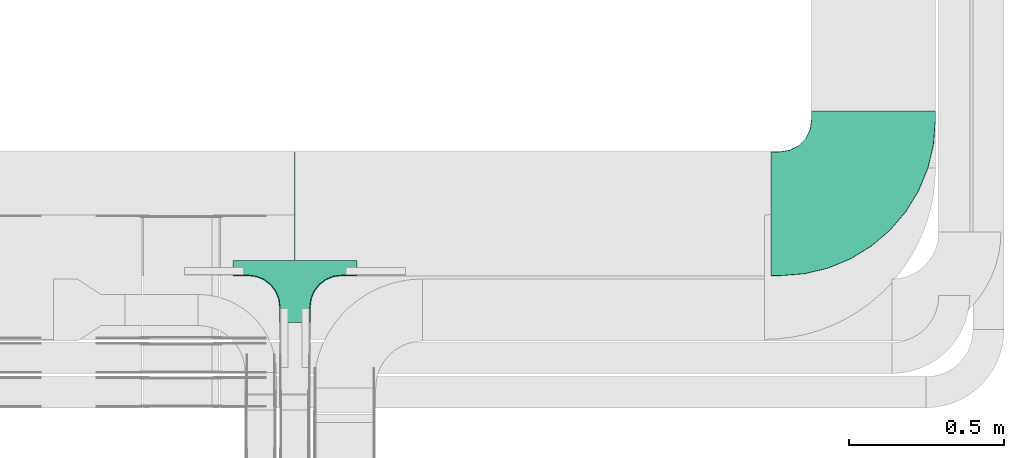
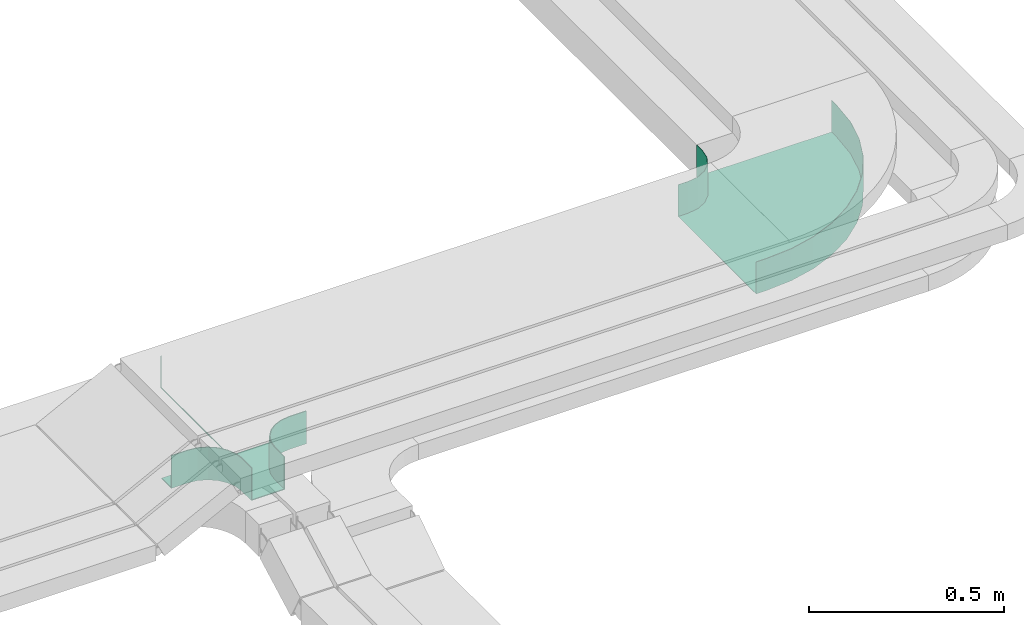
# One storey, part 28 of 28: 2 flow fittings.
"""IFC2X3 building model written with IfcOpenShell, lengths in millimetres."""

from ifc_helpers import new_model, entity, si_unit, converted_unit, derived_unit, direction, frame, origin, place, context, subcontext, project, spatial, faceted_brep, source, transform, mapped, material, type_object, type_shapes, element, save


model = new_model("IFC2X3")

# Units and contexts
model_context = context("Model", 3, precision=0.01, world=origin(), true_north=direction((6.12303176911189e-17, 1.0)))
body_context = subcontext(model_context, "Body", "Model", "MODEL_VIEW")
ifc_project = project(units=[si_unit("LENGTHUNIT", "METRE", prefix="MILLI"), si_unit("AREAUNIT", "SQUARE_METRE"), si_unit("VOLUMEUNIT", "CUBIC_METRE"), converted_unit("PLANEANGLEUNIT", "DEGREE", entity("IfcRatioMeasure", 0.0174532925199433), si_unit("PLANEANGLEUNIT", "RADIAN"), dimensions=[0, 0, 0, 0, 0, 0, 0]), si_unit("MASSUNIT", "GRAM", prefix="KILO"), derived_unit("MASSDENSITYUNIT", [(si_unit("MASSUNIT", "GRAM", prefix="KILO"), 1), (si_unit("LENGTHUNIT", "METRE"), -3)]), derived_unit("MOMENTOFINERTIAUNIT", [(si_unit("LENGTHUNIT", "METRE"), 4)]), si_unit("TIMEUNIT", "SECOND"), si_unit("FREQUENCYUNIT", "HERTZ"), si_unit("THERMODYNAMICTEMPERATUREUNIT", "DEGREE_CELSIUS"), derived_unit("THERMALTRANSMITTANCEUNIT", [(si_unit("MASSUNIT", "GRAM", prefix="KILO"), 1), (si_unit("THERMODYNAMICTEMPERATUREUNIT", "KELVIN"), -1), (si_unit("TIMEUNIT", "SECOND"), -3)]), derived_unit("VOLUMETRICFLOWRATEUNIT", [(si_unit("LENGTHUNIT", "METRE"), 3), (si_unit("TIMEUNIT", "SECOND"), -1)]), derived_unit("MASSFLOWRATEUNIT", [(si_unit("MASSUNIT", "GRAM", prefix="KILO"), 1), (si_unit("TIMEUNIT", "SECOND"), -1)]), derived_unit("ROTATIONALFREQUENCYUNIT", [(si_unit("TIMEUNIT", "SECOND"), -1)]), si_unit("ELECTRICCURRENTUNIT", "AMPERE"), si_unit("ELECTRICVOLTAGEUNIT", "VOLT"), si_unit("POWERUNIT", "WATT"), si_unit("FORCEUNIT", "NEWTON", prefix="KILO"), si_unit("ILLUMINANCEUNIT", "LUX"), si_unit("LUMINOUSFLUXUNIT", "LUMEN"), si_unit("LUMINOUSINTENSITYUNIT", "CANDELA"), derived_unit("USERDEFINED", [(si_unit("MASSUNIT", "GRAM", prefix="KILO"), -1), (si_unit("LENGTHUNIT", "METRE"), -2), (si_unit("TIMEUNIT", "SECOND"), 3), (si_unit("LUMINOUSFLUXUNIT", "LUMEN"), 1)]), derived_unit("LINEARVELOCITYUNIT", [(si_unit("LENGTHUNIT", "METRE"), 1), (si_unit("TIMEUNIT", "SECOND"), -1)]), si_unit("PRESSUREUNIT", "PASCAL"), derived_unit("USERDEFINED", [(si_unit("LENGTHUNIT", "METRE"), -2), (si_unit("MASSUNIT", "GRAM", prefix="KILO"), 1), (si_unit("TIMEUNIT", "SECOND"), -2)]), derived_unit("LINEARFORCEUNIT", [(si_unit("MASSUNIT", "GRAM", prefix="KILO"), 1), (si_unit("LENGTHUNIT", "METRE"), 1), (si_unit("TIMEUNIT", "SECOND"), -2), (si_unit("LENGTHUNIT", "METRE"), -1)]), derived_unit("PLANARFORCEUNIT", [(si_unit("MASSUNIT", "GRAM", prefix="KILO"), 1), (si_unit("LENGTHUNIT", "METRE"), 1), (si_unit("TIMEUNIT", "SECOND"), -2), (si_unit("LENGTHUNIT", "METRE"), -2)])], contexts=[model_context])

# Site, building, storey
site_placement = place(None, frame((0.0, -0.00077364408347762, 0.0)))
site = spatial("IfcSite", under=ifc_project, at=site_placement, CompositionType="ELEMENT")
building_placement = place(site_placement, origin())
building = spatial("IfcBuilding", under=site, at=building_placement, CompositionType="ELEMENT")
storey_placement = place(building_placement, origin())
storey = spatial("IfcBuildingStorey", under=building, at=storey_placement, CompositionType="ELEMENT", Elevation=0.0)

# Flow fittings
ifc_material_1 = material()
cable_carrier_fitting_type_1 = type_object("IfcCableCarrierFittingType", PredefinedType="NOTDEFINED", material=ifc_material_1)
shared_shape_1 = source(origin(), body_context, "Body", "Brep", [
    faceted_brep([(1.0, 197.500000000001, 50.0), (1.0, 197.500000000001, -47.500000000001), (1.0, -200.0, -47.500000000001), (1.0, -200.0, -50.0), (1.0, 200.0, -50.0), (1.0, 200.0, 50.0), (-1.0, 197.500000000001, 50.0), (-1.0, 200.0, 50.0), (-1.0, 200.0, -50.0), (-1.0, -200.0, -50.0), (-1.0, -200.0, -47.500000000001), (-1.0, 197.500000000001, -47.500000000001)], [[[0, 1, 2, 3, 4, 5]], [[6, 7, 8, 9, 10, 11]], [[1, 0, 6, 11]], [[2, 1, 11, 10]], [[3, 2, 10, 9]], [[4, 3, 9, 8]], [[5, 4, 8, 7]], [[0, 5, 7, 6]]]),
    faceted_brep([(47.4999999999995, -300.0, 50.0), (47.4999999999995, -350.0, 50.0), (50.0, -350.0, 50.0), (50.0, -300.0, 50.0), (53.4074173710929, -274.118095489749, 50.0), (63.3974596215558, -250.0, 50.0), (79.2893218813448, -229.289321881346, 50.0), (100.0, -213.397459621557, 50.0), (124.118095489747, -203.407417371094, 50.0), (150.0, -200.0, 50.0), (200.0, -200.0, 50.0), (200.0, -197.500000000001, 50.0), (150.0, -197.500000000001, 50.0), (123.471047876992, -200.992602805371, 50.0), (98.75, -211.232396112096, 50.0), (77.5215549283788, -227.521554928379, 50.0), (61.2323961120949, -248.750000000001, 50.0), (50.9926028053703, -273.471047876992, 50.0), (-124.118095489753, -203.407417371094, 50.0), (-100.0, -213.397459621557, 50.0), (-79.289321881351, -229.289321881346, 50.0), (-63.3974596215619, -250.0, 50.0), (-53.407417371099, -274.118095489749, 50.0), (-50.0, -300.0, 50.0), (-50.0, -350.0, 50.0), (-47.5000000000058, -350.0, 50.0), (-47.5000000000059, -300.0, 50.0), (-50.9926028053763, -273.471047876993, 50.0), (-61.2323961121008, -248.750000000001, 50.0), (-77.5215549283845, -227.52155492838, 50.0), (-98.7500000000056, -211.232396112096, 50.0), (-123.471047876997, -200.992602805371, 50.0), (-150.0, -197.500000000001, 50.0), (-200.0, -197.500000000001, 50.0), (-200.0, -200.0, 50.0), (-150.0, -200.0, 50.0), (-124.118095489754, -203.407417371094, -50.0), (-139.212641733723, -201.420182658132, -50.0), (-150.0, -200.0, -50.0), (-150.0, -200.0, -52.5000000000001), (-137.05904774488, -201.703708685552, -52.5000000000001), (-124.118095489753, -203.407417371099, -52.5000000000001), (-100.0, -213.397459621557, -50.0), (-112.059047744882, -208.402438496329, -50.0), (-112.05904774488, -208.40243849633, -52.5000000000001), (-100.0, -213.397459621562, -52.5000000000001), (-89.6446609406813, -221.343390751454, -50.0), (-79.2893218813514, -229.289321881346, -50.0), (-89.6446609406784, -221.343390751456, -52.5000000000001), (-79.2893218813506, -229.289321881351, -52.5000000000001), (-53.4074173710992, -274.118095489748, -50.0), (-58.4024384963323, -262.059047744874, -50.0), (-63.3974596215623, -250.0, -50.0), (-63.3974596215616, -250.0, -52.5000000000001), (-58.4024384963304, -262.059047744879, -52.5000000000001), (-53.4074173710987, -274.118095489754, -52.5000000000001), (-50.0, -300.0, -50.0), (-51.7037086855529, -287.059047744874, -50.0), (-51.420182658065, -289.21264173423, -52.5000000000001), (-50.0, -300.0, -52.5000000000001), (-71.3433907514592, -239.644660940674, -50.0), (-71.3433907514565, -239.644660940678, -52.5000000000001), (-50.0, -350.0, -52.5000000000001), (50.0, -350.0, -52.5000000000001), (47.4999999999995, -350.0, -50.0), (-47.5000000000058, -350.0, -50.0), (-47.5000000000058, -300.0, -50.0), (-50.9926028053762, -273.471047876993, -50.0), (-61.2323961121005, -248.750000000002, -50.0), (-77.5215549283841, -227.52155492838, -50.0), (-98.750000000005, -211.232396112096, -50.0), (-123.471047876996, -200.992602805372, -50.0), (-150.0, -197.500000000001, -50.0), (50.0, -300.0, -52.5000000000001), (50.0, -300.0, -50.0), (53.4074173710928, -274.11809548975, -50.0), (58.4024384963256, -262.059047744877, -50.0), (63.3974596215555, -250.0, -50.0), (53.4074173710929, -274.118095489754, -52.5000000000001), (58.402438496324, -262.059047744881, -52.5000000000001), (63.3974596215557, -250.0, -52.5000000000001), (71.343390751452, -239.644660940677, -50.0), (79.2893218813444, -229.289321881347, -50.0), (71.3433907514499, -239.644660940679, -52.5000000000001), (79.2893218813448, -229.289321881352, -52.5000000000001), (51.4201826582159, -289.212641733042, -50.0), (51.7037086855462, -287.059047744881, -52.5), (100.0, -213.397459621557, -50.0), (112.059047744874, -208.40243849633, -50.0), (124.118095489747, -203.407417371094, -50.0), (100.0, -213.397459621562, -52.5000000000001), (112.059047744873, -208.402438496331, -52.5000000000001), (124.118095489748, -203.407417371099, -52.5000000000001), (137.059047744873, -201.703708685553, -50.0), (150.0, -200.0, -50.0), (139.212641734219, -201.420182658066, -52.5000000000001), (150.0, -200.0, -52.5000000000001), (89.6446609406736, -221.343390751456, -50.0), (89.6446609406717, -221.343390751457, -52.5000000000001), (123.471047876991, -200.992602805371, -50.0), (98.7499999999995, -211.232396112096, -50.0), (77.5215549283783, -227.52155492838, -50.0), (150.0, -197.500000000001, -50.0), (61.2323961120945, -248.750000000001, -50.0), (50.9926028053701, -273.471047876993, -50.0), (47.4999999999997, -300.0, -50.0), (-200.0, -197.500000000001, -50.0), (200.0, -197.500000000001, -50.0), (-200.0, -150.0, -50.0), (-200.0, -150.0, -52.5000000000001), (-200.0, -200.0, -52.5000000000001), (200.0, -200.0, -52.5000000000001), (200.0, -150.0, -52.5000000000001), (200.0, -150.0, -50.0)], [[[0, 1, 2, 3, 4, 5, 6, 7, 8, 9, 10, 11, 12, 13, 14, 15, 16, 17]], [[18, 19, 20, 21, 22, 23, 24, 25, 26, 27, 28, 29, 30, 31, 32, 33, 34, 35]], [[18, 35, 36]], [[35, 37, 36]], [[35, 38, 37]], [[37, 38, 39]], [[37, 39, 40]], [[36, 40, 41]], [[37, 40, 36]], [[19, 18, 42]], [[18, 43, 42]], [[18, 36, 43]], [[36, 41, 43]], [[44, 43, 41]], [[43, 44, 42]], [[44, 45, 42]], [[19, 42, 46]], [[19, 46, 47]], [[47, 20, 19]], [[46, 42, 45]], [[46, 45, 48]], [[48, 49, 47]], [[46, 48, 47]], [[22, 21, 50]], [[21, 51, 50]], [[21, 52, 51]], [[52, 53, 51]], [[54, 51, 53]], [[51, 54, 50]], [[54, 55, 50]], [[23, 22, 56]], [[22, 57, 56]], [[22, 50, 57]], [[50, 55, 57]], [[58, 57, 55]], [[58, 59, 56]], [[57, 58, 56]], [[20, 47, 60]], [[20, 60, 52]], [[52, 21, 20]], [[60, 47, 49]], [[60, 49, 61]], [[60, 61, 52]], [[61, 53, 52]], [[24, 23, 56, 59, 62]], [[25, 24, 62, 63, 2, 1, 64, 65]], [[26, 25, 65, 66]], [[27, 67, 68, 28]], [[28, 68, 69, 29]], [[66, 67, 27, 26]], [[30, 70, 71, 31]], [[31, 71, 72, 32]], [[29, 69, 70, 30]], [[3, 2, 63, 73, 74]], [[5, 4, 75]], [[5, 75, 76]], [[5, 76, 77]], [[75, 78, 76]], [[79, 76, 78]], [[76, 79, 77]], [[79, 80, 77]], [[6, 5, 77]], [[6, 77, 81]], [[6, 81, 82]], [[81, 77, 80]], [[81, 80, 83]], [[83, 84, 82]], [[81, 83, 82]], [[74, 4, 3]], [[4, 74, 85]], [[85, 74, 73]], [[85, 73, 86]], [[85, 86, 75]], [[75, 86, 78]], [[4, 85, 75]], [[8, 7, 87]], [[8, 87, 88]], [[8, 88, 89]], [[87, 90, 88]], [[91, 88, 90]], [[88, 91, 89]], [[91, 92, 89]], [[9, 8, 89]], [[9, 89, 93]], [[9, 93, 94]], [[89, 92, 93]], [[95, 93, 92]], [[95, 96, 94]], [[93, 95, 94]], [[7, 82, 97]], [[6, 82, 7]], [[7, 97, 87]], [[97, 82, 84]], [[97, 84, 98]], [[97, 98, 87]], [[98, 90, 87]], [[13, 99, 100, 14]], [[14, 100, 101, 15]], [[102, 99, 13, 12]], [[16, 103, 104, 17]], [[17, 104, 105, 0]], [[15, 101, 103, 16]], [[1, 0, 105, 64]], [[33, 32, 72, 106]], [[12, 11, 107, 102]], [[34, 33, 106, 108, 109, 110]], [[35, 34, 110, 39, 38]], [[10, 9, 94, 96, 111]], [[10, 111, 112, 113, 107, 11]], [[107, 113, 108, 106, 72, 71, 70, 69, 68, 67, 66, 65, 64, 105, 104, 103, 101, 100, 99, 102]], [[110, 109, 112, 111, 96, 95, 92, 91, 90, 98, 84, 83, 80, 79, 78, 86, 73, 63, 62, 59, 58, 55, 54, 53, 61, 49, 48, 45, 44, 41, 40, 39]], [[108, 113, 112, 109]]]),
])
type_shapes(cable_carrier_fitting_type_1, [shared_shape_1])
flow_fitting_1_placement = place(storey_placement, frame((66384.9973266601, 8924.32755701973, 2650.0)))
element("IfcFlowFitting", 1, at=flow_fitting_1_placement, inside=storey, type_object=cable_carrier_fitting_type_1, material=ifc_material_1, context=body_context, shape_type="MappedRepresentation", body=[
    mapped(shared_shape_1, transform((0.0, 0.0, 0.0), scale=1.0)),
])
ifc_material_2 = material()
cable_carrier_fitting_type_2 = type_object("IfcCableCarrierFittingType", Name="470_DKC_S5_CPO 45 horizontal angle:-", PredefinedType="NOTDEFINED", material=ifc_material_2)
shared_shape_2 = source(origin(), body_context, "Body", "Brep", [
    faceted_brep([(-330.0, -200.0, -50.0), (-330.0, -200.0, 50.0), (-330.0, -199.200000000008, 50.0), (-330.0, -199.200000000008, -49.2000000000019), (-330.0, 199.199999999992, -49.2000000000019), (-330.0, 199.199999999992, 50.0), (-330.0, 200.0, 50.0), (-330.0, 200.0, -50.0), (-300.0, -200.0, -50.0), (-300.0, -200.0, 50.0), (-221.782767479876, -193.844170297577, 50.0), (-145.491502812517, -175.528258147585, 50.0), (-73.0047501302177, -145.503262094192, 50.0), (-6.10737385375454, -104.508497187482, 50.0), (53.5533905932826, -53.5533905932825, 50.0), (104.508497187483, 6.10737385375464, 50.0), (145.503262094193, 73.0047501302177, 50.0), (175.528258147586, 145.491502812517, 50.0), (193.844170297578, 221.782767479875, 50.0), (200.0, 300.0, 50.0), (200.0, 330.0, 50.0), (199.200000000009, 330.0, 50.0), (199.200000000009, 300.0, 50.0), (193.054019625102, 221.907915051908, 50.0), (174.76741293455, 145.738716408017, 50.0), (144.790456874842, 73.3679425300094, 50.0), (103.861283591982, 6.5776020555887, 50.0), (52.9877051683332, -52.9877051683332, 50.0), (-6.5776020555887, -103.861283591982, 50.0), (-73.3679425300094, -144.790456874842, 50.0), (-145.738716408017, -174.767412934549, 50.0), (-221.907915051908, -193.054019625101, 50.0), (-300.0, -199.200000000008, 50.0), (-300.0, 199.199999999992, 50.0), (-268.851086966996, 204.13350315744, 50.0), (-240.75124656891, 218.451086966997, 50.0), (-218.451086966996, 240.75124656891, 50.0), (-204.13350315744, 268.851086966997, 50.0), (-199.199999999991, 300.0, 50.0), (-199.199999999991, 330.0, 50.0), (-200.0, 330.0, 50.0), (-200.0, 300.0, 50.0), (-204.894348370476, 269.098300562497, 50.0), (-219.098300562496, 241.221474770744, 50.0), (-241.221474770744, 219.098300562497, 50.0), (-269.098300562496, 204.894348370476, 50.0), (-300.0, 200.0, 50.0), (-300.0, -199.200000000008, -49.2000000000019), (-221.907915051908, -193.054019625101, -49.2000000000018), (-145.738716408017, -174.767412934549, -49.2000000000018), (-73.3679425300094, -144.790456874842, -49.2000000000018), (-6.5776020555887, -103.861283591982, -49.2000000000018), (52.9877051683332, -52.9877051683332, -49.2000000000018), (103.861283591982, 6.5776020555887, -49.2000000000018), (144.790456874842, 73.3679425300094, -49.2000000000017), (174.76741293455, 145.738716408017, -49.2000000000017), (193.054019625102, 221.907915051908, -49.2000000000017), (199.200000000009, 300.0, -49.2000000000017), (199.200000000009, 330.0, -49.2000000000017), (-199.199999999991, 330.0, -49.2000000000018), (-199.199999999991, 300.0, -49.2000000000018), (-204.13350315744, 268.851086966997, -49.2000000000018), (-218.451086966996, 240.75124656891, -49.2000000000018), (-240.75124656891, 218.451086966997, -49.2000000000019), (-268.851086966996, 204.13350315744, -49.2000000000019), (-300.0, 199.199999999992, -49.2000000000019), (-300.0, 200.0, -50.0), (-221.782767479876, -193.844170297577, -50.0), (-269.098300562496, 204.894348370476, -50.0), (-241.221474770744, 219.098300562497, -50.0), (-219.098300562496, 241.221474770744, -50.0), (-204.894348370476, 269.098300562497, -50.0), (-200.0, 300.0, -50.0), (-200.0, 330.0, -50.0), (200.0, 330.0, -50.0), (200.0, 300.0, -50.0), (193.844170297578, 221.782767479875, -50.0), (175.528258147586, 145.491502812517, -50.0), (145.503262094193, 73.0047501302177, -50.0), (104.508497187483, 6.10737385375464, -50.0), (53.5533905932826, -53.5533905932825, -50.0), (-6.10737385375454, -104.508497187482, -50.0), (-73.0047501302177, -145.503262094192, -50.0), (-145.491502812517, -175.528258147585, -50.0)], [[[0, 1, 2, 3, 4, 5, 6, 7]], [[1, 0, 8, 9]], [[1, 9, 10, 11, 12, 13, 14, 15, 16, 17, 18, 19, 20, 21, 22, 23, 24, 25, 26, 27, 28, 29, 30, 31, 32, 2]], [[6, 5, 33, 34, 35, 36, 37, 38, 39, 40, 41, 42, 43, 44, 45, 46]], [[3, 2, 32, 47]], [[4, 3, 47, 48, 49, 50, 51, 52, 53, 54, 55, 56, 57, 58, 59, 60, 61, 62, 63, 64, 65]], [[5, 4, 65, 33]], [[7, 6, 46, 66]], [[67, 8, 0, 7, 66, 68, 69, 70, 71, 72, 73, 74, 75, 76, 77, 78, 79, 80, 81, 82, 83]], [[10, 9, 8, 67]], [[67, 83, 11, 10]], [[82, 12, 11, 83]], [[12, 82, 81, 13]], [[14, 13, 81, 80]], [[15, 79, 78, 16]], [[17, 77, 76, 18]], [[78, 77, 17, 16]], [[18, 76, 75, 19]], [[79, 15, 14, 80]], [[48, 47, 32, 31]], [[30, 49, 48, 31]], [[49, 30, 29, 50]], [[28, 51, 50, 29]], [[51, 28, 27, 52]], [[54, 53, 26, 25]], [[56, 55, 24, 23]], [[25, 24, 55, 54]], [[57, 56, 23, 22]], [[27, 26, 53, 52]], [[64, 63, 35, 34]], [[65, 64, 34, 33]], [[63, 62, 36, 35]], [[36, 62, 61, 37]], [[37, 61, 60, 38]], [[45, 44, 69, 68]], [[45, 68, 66, 46]], [[44, 43, 70, 69]], [[71, 70, 43, 42]], [[72, 71, 42, 41]], [[73, 40, 39, 59, 58, 21, 20, 74]], [[19, 75, 74, 20]], [[57, 22, 21, 58]], [[38, 60, 59, 39]], [[72, 41, 40, 73]]]),
])
type_shapes(cable_carrier_fitting_type_2, [shared_shape_2])
flow_fitting_2_placement = place(storey_placement, frame((68246.0094990459, 8924.32755701971, 2650.0)))
element("IfcFlowFitting", 2, at=flow_fitting_2_placement, inside=storey, type_object=cable_carrier_fitting_type_2, material=ifc_material_2, Name="470_DKC_S5_45 horizontal angle", ObjectType="470_DKC_S5_CPO 45 horizontal angle:-", context=body_context, shape_type="MappedRepresentation", body=[
    mapped(shared_shape_2, transform((0.0, 0.0, 0.0), scale=1.0)),
])

save(model, "model.ifc")
